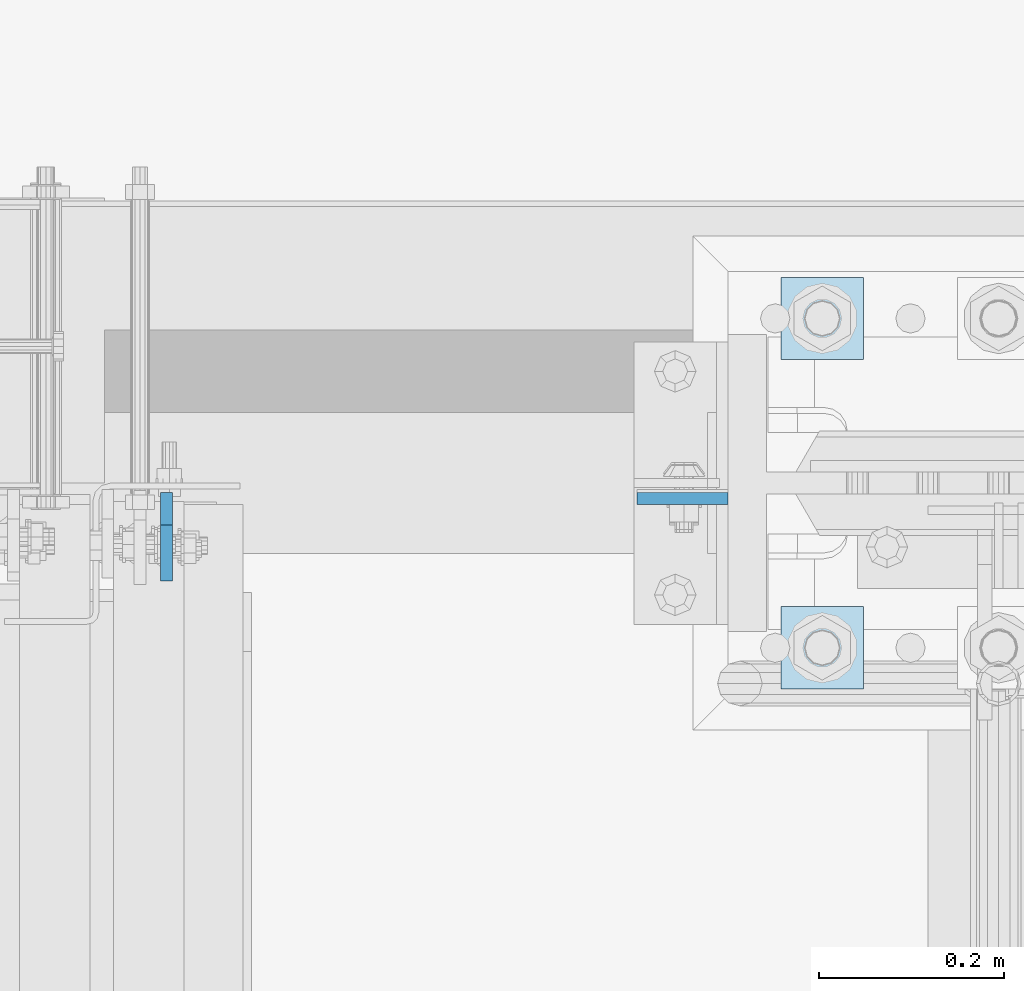
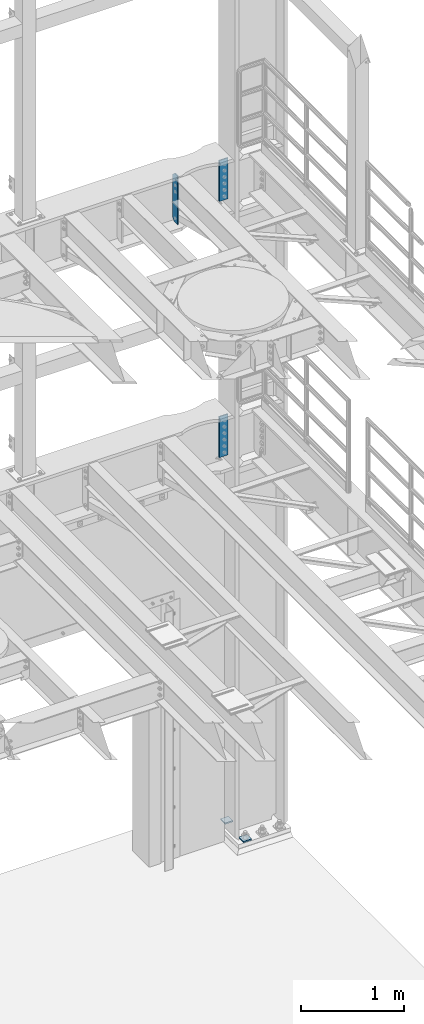
# One storey, part 1812 of 1876: 5 plates, 3 elements without a shape of their own.
"""IFC2X3 building model written with IfcOpenShell, lengths in millimetres."""

from ifc_helpers import new_model, si_unit, frame, origin_with_axes, place, context, subcontext, project, spatial, faceted_brep, material, type_object, element, aggregate, save


model = new_model("IFC2X3")

# Units and contexts
model_context = context("Model", 3, precision=1e-05, world=origin_with_axes())
body_context = subcontext(model_context, "Body", "Model", "MODEL_VIEW")
ifc_project = project(units=[si_unit("LENGTHUNIT", "METRE", prefix="MILLI"), si_unit("AREAUNIT", "SQUARE_METRE"), si_unit("VOLUMEUNIT", "CUBIC_METRE"), si_unit("MASSUNIT", "GRAM", prefix="KILO"), si_unit("TIMEUNIT", "SECOND"), si_unit("PLANEANGLEUNIT", "RADIAN"), si_unit("SOLIDANGLEUNIT", "STERADIAN"), si_unit("THERMODYNAMICTEMPERATUREUNIT", "DEGREE_CELSIUS"), si_unit("LUMINOUSINTENSITYUNIT", "LUMEN")], contexts=[model_context])

# Site, building, storey
site_placement = place(None, origin_with_axes())
site = spatial("IfcSite", under=ifc_project, at=site_placement, CompositionType="ELEMENT")
building_placement = place(site_placement, origin_with_axes())
building = spatial("IfcBuilding", under=site, at=building_placement, Name="Undefined", CompositionType="ELEMENT")
storey_placement = place(building_placement, origin_with_axes())
storey = spatial("IfcBuildingStorey", under=building, at=storey_placement, Name="Undefined", CompositionType="ELEMENT", Elevation=0.0)

# Assembly, plates
assembly_1_placement = place(storey_placement, origin_with_axes())
assembly_1 = element("IfcElementAssembly", 1, at=assembly_1_placement, inside=storey, Name="COLUMN", AssemblyPlace="NOTDEFINED", PredefinedType="RIGID_FRAME")
ifc_material_1 = material(Name="STEEL/A572-50")
plate_type_1 = type_object("IfcPlateType", PredefinedType="NOTDEFINED")
plate_1_placement = place(assembly_1_placement, frame((7327.9, 13699.3320001602, 8070.85), z_axis=(-1.0, 0.0, 0.0), x_axis=(0.0, 0.0, -1.0)))
plate_1 = element("IfcPlate", 2, at=plate_1_placement, type_object=plate_type_1, material=ifc_material_1, Name="PLATE", context=body_context, shape_type="Brep", body=[
    faceted_brep([(0.0, -6.35000000000036, 0.0), (0.0, -6.34999999999991, 98.4250030517578), (0.0, 6.34999999999991, 98.4250030517578), (0.0, 6.35000000000036, 0.0), (482.600006103516, -6.35000000000036, 98.4250030517578), (482.600006103516, 6.35000000000036, 98.4250030517578), (482.600006103516, -6.35000000000036, 0.0), (482.600006103516, 6.35000000000036, 0.0)], [[[0, 1, 2, 3]], [[1, 4, 5, 2]], [[4, 6, 7, 5]], [[6, 0, 3, 7]], [[5, 7, 3, 2]], [[6, 4, 1, 0]]]),
])
plate_2_placement = place(assembly_1_placement, frame((7327.9, 13699.3320001602, 5048.25), z_axis=(-1.0, 0.0, 0.0), x_axis=(0.0, 0.0, -1.0)))
plate_2 = element("IfcPlate", 3, at=plate_2_placement, type_object=plate_type_1, material=ifc_material_1, Name="PLATE", context=body_context, shape_type="Brep", body=[
    faceted_brep([(0.0, -6.35000000000036, 0.0), (0.0, -6.34999999999991, 98.4250030517578), (0.0, 6.34999999999991, 98.4250030517578), (0.0, 6.35000000000036, 0.0), (482.600006103516, -6.35000000000036, 98.4250030517578), (482.600006103516, 6.35000000000036, 98.4250030517578), (482.600006103516, -6.35000000000036, 0.0), (482.600006103516, 6.35000000000036, 0.0)], [[[0, 1, 2, 3]], [[1, 4, 5, 2]], [[4, 6, 7, 5]], [[6, 0, 3, 7]], [[5, 7, 3, 2]], [[6, 4, 1, 0]]]),
])
aggregate(assembly_1, [plate_1, plate_2])

# Assembly, plate
assembly_2_placement = place(storey_placement, origin_with_axes())
assembly_2 = element("IfcElementAssembly", 4, at=assembly_2_placement, inside=storey, Name="BEAM", AssemblyPlace="NOTDEFINED", PredefinedType="RIGID_FRAME")
ifc_material_2 = material(Name="STEEL/A36")
plate_type_2 = type_object("IfcPlateType", PredefinedType="NOTDEFINED")
plate_3_placement = place(assembly_2_placement, frame((6721.47499990463, 13705.68125, 7543.8), z_axis=(0.0, 0.0, 1.0), x_axis=(0.0, -1.0, 0.0)))
plate_3 = element("IfcPlate", 5, at=plate_3_placement, type_object=plate_type_2, material=ifc_material_2, Name="PLATE", context=body_context, shape_type="Brep", body=[
    faceted_brep([(0.0, -6.34999999999991, 34.9249992370605), (0.0, -6.35000000000036, 538.162475585938), (0.0, 6.35000000000036, 538.162475585938), (0.0, 6.34999999999991, 34.9249992370605), (34.9249992370605, -6.34999999999991, 573.087524414062), (34.9249992370605, 6.34999999999991, 573.087524414062), (95.25, -6.34999999999991, 573.087524414062), (95.25, 6.34999999999991, 573.087524414062), (95.25, -6.35000000000036, 0.0), (95.25, 6.35000000000036, 0.0), (34.9249992370605, -6.34999999999991, 0.0), (34.9249992370605, 6.34999999999991, 0.0)], [[[0, 1, 2, 3]], [[1, 4, 5, 2]], [[4, 6, 7, 5]], [[6, 8, 9, 7]], [[8, 10, 11, 9]], [[10, 0, 3, 11]], [[5, 7, 9, 11, 3, 2]], [[10, 8, 6, 4, 1, 0]]]),
])
aggregate(assembly_2, [plate_3])

# Assembly, plates
assembly_3_placement = place(storey_placement, origin_with_axes())
assembly_3 = element("IfcElementAssembly", 6, at=assembly_3_placement, inside=storey, Name="TEMPLATE", AssemblyPlace="NOTDEFINED", PredefinedType="RIGID_FRAME")
plate_type_3 = type_object("IfcPlateType", PredefinedType="NOTDEFINED")
plate_4_placement = place(assembly_3_placement, frame((7385.05, 13582.65, 96.8375), z_axis=(0.0, -1.0, 0.0), x_axis=(1.0, 0.0, 0.0)))
plate_4 = element("IfcPlate", 7, at=plate_4_placement, type_object=plate_type_3, material=ifc_material_1, Name="PLATE WASHER", context=body_context, shape_type="Brep", body=[
    faceted_brep([(0.0, -7.9375, 0.0), (0.0, -7.9375, 88.9000015258789), (0.0, 7.9375, 88.9000015258789), (0.0, 7.9375, 0.0), (88.9000015258789, -7.9375, 88.9000015258789), (88.9000015258789, 7.9375, 88.9000015258789), (88.9000015258789, -7.9375, 0.0), (88.9000015258789, 7.9375, 0.0)], [[[0, 1, 2, 3]], [[1, 4, 5, 2]], [[4, 6, 7, 5]], [[6, 0, 3, 7]], [[5, 7, 3, 2]], [[6, 4, 1, 0]]]),
])
plate_5_placement = place(assembly_3_placement, frame((7385.05, 13938.25, 96.8375), z_axis=(0.0, -1.0, 0.0), x_axis=(1.0, 0.0, 0.0)))
plate_5 = element("IfcPlate", 8, at=plate_5_placement, type_object=plate_type_3, material=ifc_material_1, Name="PLATE WASHER", context=body_context, shape_type="Brep", body=[
    faceted_brep([(0.0, -7.9375, 0.0), (0.0, -7.9375, 88.9000015258789), (0.0, 7.9375, 88.9000015258789), (0.0, 7.9375, 0.0), (88.9000015258789, -7.9375, 88.9000015258789), (88.9000015258789, 7.9375, 88.9000015258789), (88.9000015258789, -7.9375, 0.0), (88.9000015258789, 7.9375, 0.0)], [[[0, 1, 2, 3]], [[1, 4, 5, 2]], [[4, 6, 7, 5]], [[6, 0, 3, 7]], [[5, 7, 3, 2]], [[6, 4, 1, 0]]]),
])
aggregate(assembly_3, [plate_4, plate_5])

save(model, "model.ifc")
